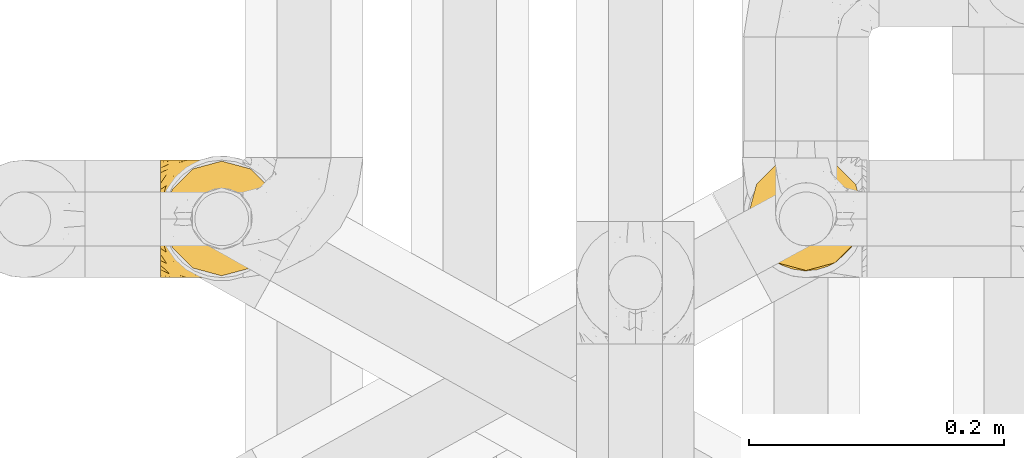
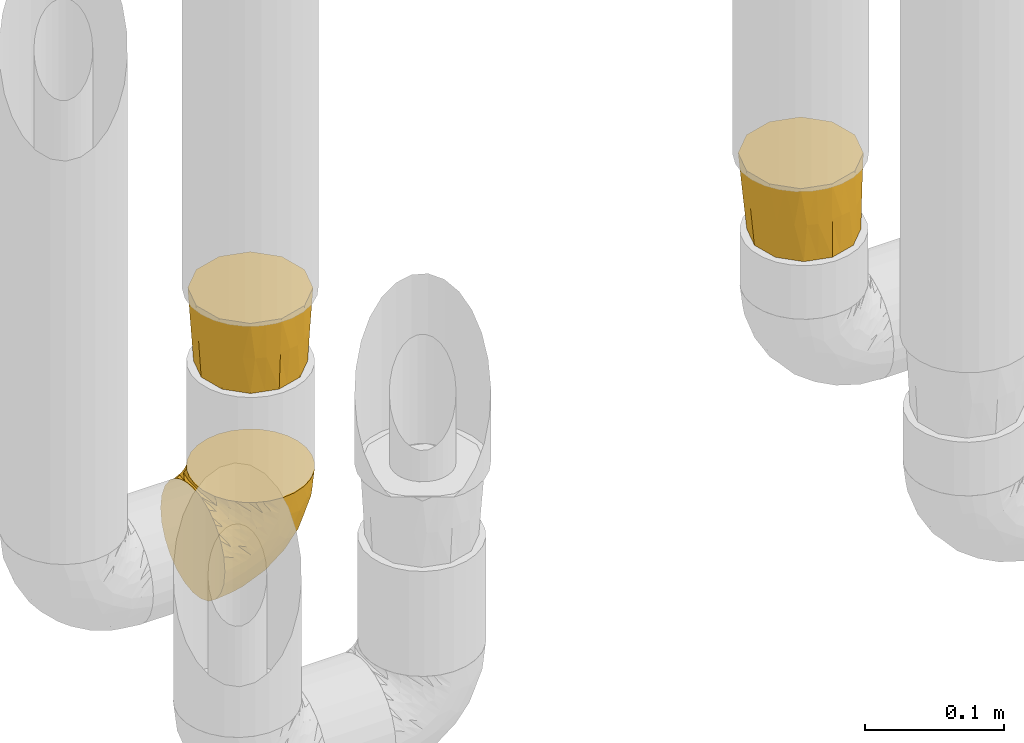
# One storey, part 177 of 827: 3 coverings.
"""IFC2X3 building model written with IfcOpenShell, lengths in millimetres."""

from ifc_helpers import new_model, entity, si_unit, converted_unit, derived_unit, direction, frame, origin, place, context, subcontext, project, spatial, faceted_brep, element, save


model = new_model("IFC2X3")

# Units and contexts
model_context = context("Model", 3, precision=0.01, world=origin(), true_north=direction((6.12303176911189e-17, 1.0)))
body_context = subcontext(model_context, "Body", "Model", "MODEL_VIEW")
ifc_project = project(units=[si_unit("LENGTHUNIT", "METRE", prefix="MILLI"), si_unit("AREAUNIT", "SQUARE_METRE"), si_unit("VOLUMEUNIT", "CUBIC_METRE"), converted_unit("PLANEANGLEUNIT", "DEGREE", entity("IfcRatioMeasure", 0.0174532925199433), si_unit("PLANEANGLEUNIT", "RADIAN"), dimensions=[0, 0, 0, 0, 0, 0, 0]), si_unit("MASSUNIT", "GRAM", prefix="KILO"), derived_unit("MASSDENSITYUNIT", [(si_unit("MASSUNIT", "GRAM", prefix="KILO"), 1), (si_unit("LENGTHUNIT", "METRE"), -3)]), derived_unit("MOMENTOFINERTIAUNIT", [(si_unit("LENGTHUNIT", "METRE"), 4)]), si_unit("TIMEUNIT", "SECOND"), si_unit("FREQUENCYUNIT", "HERTZ"), si_unit("THERMODYNAMICTEMPERATUREUNIT", "DEGREE_CELSIUS"), derived_unit("THERMALTRANSMITTANCEUNIT", [(si_unit("MASSUNIT", "GRAM", prefix="KILO"), 1), (si_unit("THERMODYNAMICTEMPERATUREUNIT", "KELVIN"), -1), (si_unit("TIMEUNIT", "SECOND"), -3)]), derived_unit("VOLUMETRICFLOWRATEUNIT", [(si_unit("LENGTHUNIT", "METRE"), 3), (si_unit("TIMEUNIT", "SECOND"), -1)]), derived_unit("MASSFLOWRATEUNIT", [(si_unit("MASSUNIT", "GRAM", prefix="KILO"), 1), (si_unit("TIMEUNIT", "SECOND"), -1)]), derived_unit("ROTATIONALFREQUENCYUNIT", [(si_unit("TIMEUNIT", "SECOND"), -1)]), si_unit("ELECTRICCURRENTUNIT", "AMPERE"), si_unit("ELECTRICVOLTAGEUNIT", "VOLT"), si_unit("POWERUNIT", "WATT"), si_unit("FORCEUNIT", "NEWTON", prefix="KILO"), si_unit("ILLUMINANCEUNIT", "LUX"), si_unit("LUMINOUSFLUXUNIT", "LUMEN"), si_unit("LUMINOUSINTENSITYUNIT", "CANDELA"), derived_unit("USERDEFINED", [(si_unit("MASSUNIT", "GRAM", prefix="KILO"), -1), (si_unit("LENGTHUNIT", "METRE"), -2), (si_unit("TIMEUNIT", "SECOND"), 3), (si_unit("LUMINOUSFLUXUNIT", "LUMEN"), 1)]), derived_unit("LINEARVELOCITYUNIT", [(si_unit("LENGTHUNIT", "METRE"), 1), (si_unit("TIMEUNIT", "SECOND"), -1)]), si_unit("PRESSUREUNIT", "PASCAL"), derived_unit("USERDEFINED", [(si_unit("LENGTHUNIT", "METRE"), -2), (si_unit("MASSUNIT", "GRAM", prefix="KILO"), 1), (si_unit("TIMEUNIT", "SECOND"), -2)]), derived_unit("LINEARFORCEUNIT", [(si_unit("MASSUNIT", "GRAM", prefix="KILO"), 1), (si_unit("LENGTHUNIT", "METRE"), 1), (si_unit("TIMEUNIT", "SECOND"), -2), (si_unit("LENGTHUNIT", "METRE"), -1)]), derived_unit("PLANARFORCEUNIT", [(si_unit("MASSUNIT", "GRAM", prefix="KILO"), 1), (si_unit("LENGTHUNIT", "METRE"), 1), (si_unit("TIMEUNIT", "SECOND"), -2), (si_unit("LENGTHUNIT", "METRE"), -2)])], contexts=[model_context])

# Site, building, storey
site_placement = place(None, origin())
site = spatial("IfcSite", under=ifc_project, at=site_placement, CompositionType="ELEMENT")
building_placement = place(site_placement, origin())
building = spatial("IfcBuilding", under=site, at=building_placement, CompositionType="ELEMENT")
storey_placement = place(building_placement, frame((0.0, 0.0, 28200.0)))
storey = spatial("IfcBuildingStorey", under=building, at=storey_placement, Name="08", CompositionType="ELEMENT", Elevation=28200.0)

# Coverings
covering_1_placement = place(storey_placement, frame((35225.75, 12958.41, 352.2)))
element("IfcCovering", 1, at=covering_1_placement, inside=storey, Name=":ADSK_", ObjectType=":ADSK_", PredefinedType="INSULATION", context=body_context, shape_type="Brep", body=[
    faceted_brep([(78.41, 11.68, 95.8), (85.72, 19.0, 95.8), (91.22, 27.76, 95.8), (94.64, 37.52, 95.8), (95.8, 47.8, 95.8), (94.64, 58.08, 95.8), (91.22, 67.85, 95.8), (85.71, 76.61, 95.8), (78.39, 83.92, 95.8), (69.63, 89.42, 95.8), (59.87, 92.84, 95.8), (49.6, 94.0, 95.8), (45.45, 93.53, 95.8), (42.38, 93.18, 95.8), (39.31, 92.84, 95.8), (34.43, 91.13, 95.8), (29.54, 89.42, 95.8), (25.16, 86.66, 95.8), (20.78, 83.91, 95.8), (17.13, 80.25, 95.8), (13.47, 76.59, 95.8), (7.97, 67.83, 95.8), (6.26, 62.95, 95.8), (4.55, 58.07, 95.8), (3.4, 47.8, 95.8), (4.55, 37.51, 95.8), (6.26, 32.63, 95.8), (7.97, 27.74, 95.8), (13.48, 18.98, 95.8), (17.14, 15.33, 95.8), (20.8, 11.67, 95.8), (25.18, 8.92, 95.8), (29.56, 6.17, 95.8), (34.44, 4.46, 95.8), (39.32, 2.75, 95.8), (42.39, 2.41, 95.8), (45.45, 2.06, 95.8), (49.6, 1.6, 95.8), (59.88, 2.75, 95.8), (69.65, 6.17, 95.8), (1.6, 47.8, 94.0), (1.6, 59.75, 92.42), (1.6, 70.9, 87.81), (1.6, 75.68, 84.13), (1.6, 80.46, 80.46), (1.6, 84.13, 75.68), (1.6, 87.81, 70.9), (1.6, 90.11, 65.32), (1.6, 92.42, 59.75), (1.6, 92.9, 56.14), (1.6, 93.17, 54.06), (1.6, 93.45, 51.97), (1.6, 94.0, 47.8), (1.6, 92.42, 35.84), (1.6, 87.81, 24.7), (1.6, 80.46, 15.13), (1.6, 70.9, 7.78), (1.6, 59.75, 3.17), (1.6, 47.8, 1.6), (1.6, 35.84, 3.17), (1.6, 24.7, 7.78), (1.6, 15.13, 15.13), (1.6, 7.78, 24.7), (1.6, 3.17, 35.84), (1.6, 1.6, 47.8), (1.6, 2.14, 51.97), (1.6, 2.69, 56.14), (1.6, 3.17, 59.75), (1.6, 5.48, 65.32), (1.6, 7.78, 70.9), (1.6, 11.46, 75.68), (1.6, 15.13, 80.46), (1.6, 19.91, 84.13), (1.6, 24.7, 87.81), (1.6, 35.84, 92.42), (36.81, 23.61, 15.84), (23.28, 31.99, 6.99), (45.8, 35.87, 14.39), (30.7, 47.8, 6.21), (21.2, 40.43, 4.26), (12.96, 47.8, 3.39), (66.19, 31.83, 31.2), (54.51, 23.37, 26.47), (17.98, 21.41, 11.44), (36.69, 3.07, 47.66), (35.54, 1.6, 61.85), (31.64, 1.6, 59.25), (27.75, 1.6, 56.65), (23.86, 1.6, 54.05), (19.96, 1.6, 51.45), (22.8, 13.45, 19.8), (42.67, 15.25, 26.22), (33.21, 8.07, 31.58), (59.45, 16.0, 38.36), (71.5, 17.34, 51.54), (62.66, 10.58, 51.6), (54.5, 5.34, 55.97), (47.57, 2.39, 62.88), (48.81, 8.36, 41.35), (74.98, 10.04, 82.24), (18.7, 2.59, 40.88), (15.75, 6.28, 29.0), (91.17, 34.28, 74.06), (85.28, 38.73, 54.53), (82.58, 27.25, 57.98), (75.78, 29.88, 43.81), (74.98, 38.6, 38.22), (67.27, 23.44, 38.33), (87.38, 25.25, 74.76), (82.04, 17.23, 76.85), (94.0, 47.8, 84.43), (77.8, 47.8, 40.43), (67.38, 47.8, 30.01), (56.2, 2.53, 78.67), (48.85, 1.6, 92.06), (48.11, 1.6, 88.32), (47.57, 1.6, 85.6), (47.03, 1.6, 82.88), (46.48, 1.6, 80.15), (45.94, 1.6, 77.43), (65.78, 5.71, 76.36), (17.24, 1.6, 50.91), (14.51, 1.6, 50.37), (11.79, 1.6, 49.82), (9.07, 1.6, 49.28), (7.2, 1.6, 48.91), (5.33, 1.6, 48.54), (91.18, 47.8, 66.69), (43.34, 1.6, 73.53), (40.74, 1.6, 69.64), (38.14, 1.6, 65.75), (72.73, 11.89, 66.13), (56.96, 47.8, 19.59), (62.23, 39.69, 24.64), (84.49, 47.8, 53.56), (43.83, 47.8, 12.9), (12.05, 13.84, 82.81), (18.95, 9.16, 81.22), (13.02, 15.79, 86.57), (8.34, 25.75, 92.75), (14.63, 16.09, 89.68), (11.09, 7.51, 72.26), (13.66, 3.99, 64.73), (20.08, 2.66, 62.45), (9.61, 3.16, 60.63), (9.48, 2.35, 56.91), (16.1, 2.23, 58.14), (3.42, 38.35, 93.7), (26.63, 6.18, 83.4), (33.72, 2.7, 75.54), (34.77, 2.93, 79.46), (6.75, 16.01, 82.28), (13.31, 9.08, 76.25), (21.11, 9.3, 84.69), (19.94, 11.68, 90.18), (8.67, 4.65, 65.12), (26.11, 3.65, 71.71), (29.3, 3.61, 75.21), (6.32, 12.8, 78.6), (39.92, 2.43, 87.27), (27.05, 6.83, 87.92), (6.04, 21.65, 86.94), (34.4, 3.7, 86.1), (2.87, 47.8, 94.52), (20.92, 3.37, 66.23), (27.43, 7.03, 91.08), (7.54, 7.87, 71.77), (18.45, 7.26, 76.21), (23.88, 3.41, 68.59), (7.77, 23.81, 89.94), (13.3, 86.5, 76.25), (11.09, 88.08, 72.26), (6.33, 82.79, 78.6), (9.07, 94.0, 49.28), (5.33, 94.0, 48.54), (14.51, 94.0, 50.37), (11.79, 94.0, 49.82), (3.42, 57.24, 93.7), (7.76, 71.76, 89.95), (47.03, 94.0, 82.88), (47.57, 94.0, 85.6), (48.85, 94.0, 92.06), (48.11, 94.0, 88.32), (14.62, 79.49, 89.68), (27.03, 88.75, 87.92), (20.08, 92.93, 62.45), (20.92, 92.22, 66.24), (27.75, 94.0, 56.65), (31.64, 94.0, 59.25), (9.61, 92.43, 60.63), (9.48, 93.24, 56.91), (8.33, 69.82, 92.76), (6.74, 79.57, 82.28), (12.04, 81.74, 82.81), (23.86, 94.0, 54.05), (19.96, 94.0, 51.45), (16.1, 93.36, 58.14), (19.93, 83.9, 90.18), (21.1, 86.28, 84.7), (39.92, 93.16, 87.25), (33.68, 92.88, 75.58), (29.28, 91.98, 75.2), (26.62, 89.41, 83.39), (26.08, 91.93, 71.7), (18.93, 86.42, 81.22), (27.87, 88.82, 90.73), (34.75, 92.66, 79.47), (6.04, 73.93, 86.94), (38.14, 94.0, 65.75), (12.79, 79.5, 86.75), (34.41, 91.89, 86.08), (45.94, 94.0, 77.43), (43.34, 94.0, 73.53), (40.74, 94.0, 69.64), (13.66, 91.6, 64.73), (17.24, 94.0, 50.91), (8.67, 90.94, 65.12), (35.54, 94.0, 61.85), (23.83, 92.16, 68.62), (18.43, 88.32, 76.22), (6.03, 86.13, 74.03), (46.48, 94.0, 80.15), (34.52, 93.2, 49.81), (21.2, 55.16, 4.26), (23.82, 82.02, 19.95), (41.32, 84.29, 30.61), (47.62, 76.94, 25.71), (52.66, 68.33, 22.43), (36.81, 71.98, 15.85), (49.75, 92.52, 60.69), (19.07, 92.9, 40.49), (45.8, 59.72, 14.39), (23.28, 63.6, 6.99), (21.35, 88.89, 29.56), (17.98, 74.18, 11.45), (82.57, 68.35, 57.98), (91.17, 61.33, 74.06), (85.27, 56.86, 54.52), (73.89, 68.62, 43.47), (66.19, 63.76, 31.2), (62.43, 72.19, 33.27), (63.53, 88.69, 64.26), (58.45, 92.19, 74.29), (67.16, 89.75, 80.41), (62.22, 55.9, 24.64), (81.54, 77.99, 73.62), (74.8, 85.21, 78.98), (75.83, 74.99, 53.69), (41.45, 90.23, 42.86), (76.72, 59.86, 41.67), (88.2, 70.75, 79.66), (71.6, 81.72, 58.41), (56.23, 86.53, 47.11), (59.44, 79.6, 38.37)], [[[0, 1, 2, 3, 4, 5, 6, 7, 8, 9, 10, 11, 12, 13, 14, 15, 16, 17, 18, 19, 20, 21, 22, 23, 24, 25, 26, 27, 28, 29, 30, 31, 32, 33, 34, 35, 36, 37, 38, 39]], [[40, 41, 42, 43, 44, 45, 46, 47, 48, 49, 50, 51, 52, 53, 54, 55, 56, 57, 58, 59, 60, 61, 62, 63, 64, 65, 66, 67, 68, 69, 70, 71, 72, 73, 74]], [[75, 76, 77]], [[78, 79, 80]], [[77, 81, 82]], [[76, 75, 83]], [[84, 85, 86, 87, 88, 89]], [[90, 91, 92]], [[76, 60, 59]], [[93, 94, 95]], [[90, 62, 61]], [[83, 61, 60]], [[96, 97, 84]], [[98, 93, 95]], [[0, 39, 99]], [[100, 84, 89]], [[62, 101, 63]], [[2, 102, 3]], [[92, 84, 100]], [[103, 102, 104]], [[103, 105, 106]], [[93, 107, 94]], [[1, 108, 2]], [[92, 101, 90]], [[108, 1, 109]], [[102, 110, 3]], [[93, 82, 107]], [[102, 108, 104]], [[111, 106, 112]], [[109, 0, 99]], [[113, 37, 114, 115, 116, 117, 118, 119]], [[120, 38, 113]], [[100, 89, 121, 122, 123, 124, 125, 126, 64]], [[127, 102, 103]], [[97, 119, 128, 129, 130, 85]], [[99, 120, 131]], [[132, 133, 77]], [[59, 80, 79]], [[1, 0, 109]], [[98, 84, 92]], [[94, 109, 131]], [[120, 39, 38]], [[93, 91, 82]], [[104, 94, 105]], [[97, 113, 119]], [[95, 120, 96]], [[83, 90, 61]], [[91, 93, 98]], [[64, 63, 100]], [[100, 63, 101]], [[77, 76, 79]], [[133, 106, 81]], [[84, 97, 85]], [[113, 96, 120]], [[113, 97, 96]], [[37, 113, 38]], [[110, 102, 127]], [[110, 4, 3]], [[103, 111, 134, 127]], [[90, 75, 91]], [[82, 81, 107]], [[91, 75, 82]], [[77, 82, 75]], [[76, 83, 60]], [[90, 83, 75]], [[105, 107, 81]], [[94, 131, 95]], [[105, 94, 107]], [[109, 94, 104]], [[120, 95, 131]], [[98, 95, 96]], [[84, 98, 96]], [[98, 92, 91]], [[106, 105, 81]], [[103, 104, 105]], [[112, 106, 133]], [[103, 106, 111]], [[112, 133, 132]], [[81, 77, 133]], [[77, 78, 135, 132]], [[120, 99, 39]], [[109, 99, 131]], [[59, 58, 80]], [[59, 79, 76]], [[90, 101, 62]], [[100, 101, 92]], [[2, 108, 102]], [[109, 104, 108]], [[78, 77, 79]], [[136, 137, 138]], [[27, 139, 140]], [[141, 142, 143]], [[144, 145, 121]], [[146, 89, 88]], [[147, 139, 25]], [[148, 149, 150]], [[136, 151, 152]], [[147, 40, 74]], [[24, 147, 25]], [[140, 153, 154]], [[33, 116, 34]], [[73, 72, 151]], [[114, 37, 36, 35, 34, 116, 115]], [[146, 155, 144]], [[156, 85, 130]], [[157, 149, 148]], [[151, 158, 152]], [[117, 33, 159]], [[29, 154, 160]], [[161, 74, 73]], [[162, 128, 119]], [[66, 65, 64, 126, 125, 124, 123, 122, 67]], [[163, 147, 24]], [[27, 140, 28]], [[149, 129, 150]], [[139, 27, 26, 25]], [[68, 144, 69]], [[129, 128, 150]], [[164, 87, 86]], [[130, 129, 149]], [[122, 145, 67]], [[154, 153, 148]], [[162, 119, 159]], [[165, 30, 160]], [[150, 160, 148]], [[128, 162, 150]], [[30, 165, 31]], [[145, 144, 68]], [[89, 146, 144]], [[87, 164, 143]], [[166, 155, 142]], [[88, 87, 143]], [[162, 160, 150]], [[160, 30, 29]], [[154, 29, 28]], [[140, 154, 28]], [[160, 154, 148]], [[140, 137, 153]], [[157, 148, 153]], [[156, 130, 157]], [[153, 137, 157]], [[157, 137, 156]], [[167, 137, 136]], [[168, 85, 156]], [[152, 168, 167]], [[167, 168, 156]], [[164, 152, 141]], [[71, 158, 72]], [[152, 167, 136]], [[88, 142, 146]], [[144, 155, 69]], [[146, 142, 155]], [[70, 166, 71]], [[142, 141, 166]], [[70, 69, 155]], [[141, 158, 71]], [[161, 73, 151]], [[138, 137, 140]], [[161, 136, 169]], [[136, 161, 151]], [[74, 161, 169]], [[152, 158, 141]], [[151, 72, 158]], [[168, 152, 164]], [[137, 167, 156]], [[164, 86, 168]], [[85, 168, 86]], [[116, 33, 117]], [[130, 149, 157]], [[67, 145, 68]], [[121, 89, 144]], [[145, 122, 121]], [[40, 147, 163]], [[169, 147, 74]], [[159, 33, 32]], [[162, 159, 32]], [[159, 119, 118, 117]], [[139, 147, 169]], [[139, 169, 138]], [[162, 32, 31]], [[141, 143, 164]], [[88, 143, 142]], [[71, 166, 141]], [[155, 166, 70]], [[139, 138, 140]], [[169, 136, 138]], [[160, 162, 165]], [[162, 31, 165]], [[170, 171, 172]], [[173, 174, 52, 51, 50, 49, 48, 175, 176]], [[177, 178, 41]], [[179, 15, 180]], [[12, 11, 181, 182, 180, 14, 13]], [[183, 21, 20]], [[19, 18, 184]], [[185, 186, 187]], [[186, 188, 187]], [[43, 172, 44]], [[189, 190, 47]], [[23, 22, 21, 191]], [[170, 192, 193]], [[40, 163, 177]], [[194, 195, 196]], [[24, 23, 177]], [[197, 198, 183]], [[199, 15, 179]], [[47, 46, 189]], [[200, 201, 202]], [[201, 203, 204]], [[205, 206, 184]], [[207, 41, 178]], [[16, 15, 199]], [[14, 180, 15]], [[202, 201, 198]], [[208, 201, 200]], [[163, 24, 177]], [[48, 47, 190]], [[196, 195, 189]], [[197, 184, 202]], [[204, 193, 209]], [[210, 211, 212]], [[206, 212, 213]], [[205, 17, 210]], [[184, 206, 202]], [[210, 212, 206]], [[185, 194, 214]], [[189, 215, 190]], [[216, 45, 214]], [[186, 171, 170]], [[189, 216, 196]], [[197, 20, 19]], [[194, 185, 187]], [[197, 183, 20]], [[184, 197, 19]], [[197, 202, 198]], [[206, 200, 202]], [[204, 183, 198]], [[201, 208, 203]], [[203, 208, 217]], [[204, 198, 201]], [[217, 188, 218]], [[193, 219, 170]], [[171, 186, 185]], [[170, 218, 186]], [[170, 219, 218]], [[42, 207, 192]], [[171, 220, 172]], [[216, 189, 46]], [[214, 194, 196]], [[44, 220, 45]], [[214, 196, 216]], [[216, 46, 45]], [[214, 45, 220]], [[192, 43, 42]], [[204, 203, 219]], [[207, 193, 192]], [[209, 193, 178]], [[41, 207, 42]], [[193, 207, 178]], [[43, 192, 172]], [[170, 172, 192]], [[204, 219, 193]], [[219, 203, 218]], [[217, 218, 203]], [[188, 186, 218]], [[206, 213, 200]], [[208, 200, 213]], [[199, 210, 16]], [[215, 189, 195]], [[215, 175, 190]], [[175, 48, 190]], [[199, 179, 221, 211]], [[210, 199, 211]], [[23, 191, 177]], [[40, 177, 41]], [[178, 177, 191]], [[21, 183, 191]], [[209, 191, 183]], [[205, 18, 17]], [[17, 16, 210]], [[171, 185, 214]], [[172, 220, 44]], [[214, 220, 171]], [[191, 209, 178]], [[204, 209, 183]], [[206, 205, 210]], [[18, 205, 184]], [[222, 195, 194, 187, 188, 217]], [[57, 223, 80]], [[224, 225, 226]], [[226, 227, 228]], [[229, 217, 208, 213, 212, 211]], [[230, 52, 174, 173, 176, 175, 215, 195]], [[231, 232, 228]], [[231, 78, 223]], [[223, 57, 232]], [[224, 233, 225]], [[233, 54, 53]], [[234, 232, 56]], [[56, 55, 234]], [[234, 224, 228]], [[235, 236, 237]], [[224, 55, 54]], [[238, 239, 240]], [[52, 230, 53]], [[241, 242, 243]], [[227, 244, 231]], [[11, 10, 242]], [[236, 6, 5]], [[7, 245, 8]], [[8, 246, 9]], [[238, 247, 235]], [[222, 229, 248]], [[242, 211, 221, 179, 180, 182, 181, 11]], [[233, 53, 230]], [[111, 112, 249]], [[250, 6, 236]], [[246, 251, 241]], [[6, 250, 7]], [[127, 236, 110]], [[248, 229, 252]], [[246, 8, 245]], [[235, 245, 250]], [[236, 5, 110]], [[235, 249, 238]], [[237, 236, 127]], [[243, 9, 246]], [[252, 229, 241]], [[56, 232, 57]], [[222, 230, 195]], [[225, 248, 252]], [[248, 233, 230]], [[54, 233, 224]], [[231, 228, 227]], [[244, 132, 231]], [[248, 225, 233]], [[226, 225, 253]], [[235, 250, 236]], [[245, 7, 250]], [[251, 246, 245]], [[243, 246, 241]], [[247, 245, 235]], [[252, 251, 253]], [[229, 222, 217]], [[230, 222, 248]], [[5, 4, 110]], [[237, 127, 134, 111]], [[238, 249, 239]], [[224, 234, 55]], [[232, 234, 228]], [[242, 241, 229]], [[10, 9, 243]], [[211, 242, 229]], [[10, 243, 242]], [[80, 223, 78]], [[80, 58, 57]], [[231, 223, 232]], [[227, 240, 239]], [[224, 226, 228]], [[240, 226, 253]], [[227, 239, 244]], [[226, 240, 227]], [[251, 247, 253]], [[240, 253, 247]], [[249, 235, 237]], [[237, 111, 249]], [[112, 132, 244]], [[112, 244, 249]], [[78, 231, 132, 135]], [[249, 244, 239]], [[247, 238, 240]], [[245, 247, 251]], [[251, 252, 241]], [[225, 252, 253]]]),
])
covering_2_placement = place(storey_placement, frame((35687.54, 12963.61, 495.0)))
element("IfcCovering", 2, at=covering_2_placement, inside=storey, Name=":ADSK_", ObjectType=":ADSK_", PredefinedType="INSULATION", context=body_context, shape_type="Brep", body=[
    faceted_brep([(85.57, 69.57, 64.0), (77.33, 77.81, 64.0), (69.1, 86.04, 64.0), (57.85, 89.06, 64.0), (46.6, 92.07, 64.0), (35.35, 89.06, 64.0), (24.1, 86.04, 64.0), (15.86, 77.81, 64.0), (7.62, 69.57, 64.0), (4.61, 58.32, 64.0), (1.6, 47.07, 64.0), (4.61, 35.82, 64.0), (7.62, 24.57, 64.0), (15.86, 16.33, 64.0), (24.1, 8.1, 64.0), (35.35, 5.08, 64.0), (46.6, 2.07, 64.0), (57.85, 5.08, 64.0), (69.1, 8.1, 64.0), (77.33, 16.33, 64.0), (85.57, 24.57, 64.0), (88.58, 35.82, 64.0), (91.6, 47.07, 64.0), (88.58, 58.32, 64.0), (82.1, 22.1, 0.0), (74.6, 14.59, 0.0), (67.1, 7.09, 0.0), (54.39, 3.68, 0.0), (46.6, 1.6, 0.0), (36.35, 4.34, 0.0), (26.1, 7.09, 0.0), (18.59, 14.59, 0.0), (11.09, 22.1, 0.0), (7.68, 34.8, 0.0), (5.6, 42.6, 0.0), (8.34, 52.85, 0.0), (11.09, 63.1, 0.0), (18.59, 70.6, 0.0), (26.1, 78.1, 0.0), (38.82, 81.51, 0.0), (46.6, 83.6, 0.0), (56.85, 80.85, 0.0), (67.1, 78.1, 0.0), (74.6, 70.6, 0.0), (82.1, 63.1, 0.0), (85.51, 50.37, 0.0), (87.6, 42.6, 0.0), (84.85, 32.35, 0.0), (30.14, 84.56, 32.0), (38.19, 87.19, 33.43), (46.6, 87.93, 32.75), (22.25, 80.28, 32.0), (4.94, 55.52, 32.0), (12.48, 71.01, 32.0), (7.79, 63.36, 32.0), (3.55, 44.89, 32.75), (6.87, 28.38, 32.0), (4.33, 36.52, 33.43), (11.15, 20.49, 32.0), (35.91, 3.18, 32.0), (20.42, 10.72, 32.0), (28.07, 6.03, 32.0), (46.6, 1.84, 32.85), (63.05, 5.11, 32.0), (55.0, 2.67, 33.43), (70.94, 9.39, 32.0), (88.25, 34.14, 32.0), (80.71, 18.66, 32.0), (85.4, 26.31, 32.0), (89.65, 44.89, 32.85), (86.32, 61.29, 32.0), (88.86, 53.34, 33.43), (82.04, 69.18, 32.0), (57.28, 86.48, 32.0), (72.77, 78.95, 32.0), (65.12, 83.64, 32.0)], [[[0, 1, 2, 3, 4, 5, 6, 7, 8, 9, 10, 11, 12, 13, 14, 15, 16, 17, 18, 19, 20, 21, 22, 23]], [[24, 25, 26, 27, 28, 29, 30, 31, 32, 33, 34, 35, 36, 37, 38, 39, 40, 41, 42, 43, 44, 45, 46, 47]], [[39, 48, 49]], [[39, 50, 40]], [[48, 39, 38]], [[6, 5, 48]], [[51, 6, 48]], [[48, 5, 49]], [[10, 9, 52]], [[53, 51, 37]], [[51, 48, 38]], [[8, 53, 54]], [[54, 53, 36]], [[37, 36, 53]], [[51, 38, 37]], [[50, 49, 4]], [[53, 7, 51]], [[7, 6, 51]], [[7, 53, 8]], [[52, 9, 54]], [[54, 35, 52]], [[54, 36, 35]], [[4, 49, 5]], [[9, 8, 54]], [[34, 55, 10, 52]], [[39, 49, 50]], [[34, 52, 35]], [[33, 56, 57]], [[33, 55, 34]], [[56, 33, 32]], [[12, 11, 56]], [[58, 12, 56]], [[56, 11, 57]], [[16, 15, 59]], [[60, 58, 31]], [[58, 56, 32]], [[14, 60, 61]], [[61, 60, 30]], [[31, 30, 60]], [[58, 32, 31]], [[55, 57, 10]], [[60, 13, 58]], [[13, 12, 58]], [[13, 60, 14]], [[59, 15, 61]], [[61, 29, 59]], [[61, 30, 29]], [[10, 57, 11]], [[15, 14, 61]], [[28, 62, 16, 59]], [[33, 57, 55]], [[28, 59, 29]], [[27, 63, 64]], [[27, 62, 28]], [[63, 27, 26]], [[18, 17, 63]], [[65, 18, 63]], [[63, 17, 64]], [[22, 21, 66]], [[67, 65, 25]], [[65, 63, 26]], [[20, 67, 68]], [[68, 67, 24]], [[25, 24, 67]], [[65, 26, 25]], [[62, 64, 16]], [[67, 19, 65]], [[19, 18, 65]], [[19, 67, 20]], [[66, 21, 68]], [[68, 47, 66]], [[68, 24, 47]], [[16, 64, 17]], [[21, 20, 68]], [[46, 69, 22, 66]], [[27, 64, 62]], [[46, 66, 47]], [[45, 70, 71]], [[45, 69, 46]], [[70, 45, 44]], [[0, 23, 70]], [[72, 0, 70]], [[70, 23, 71]], [[4, 3, 73]], [[74, 72, 43]], [[72, 70, 44]], [[2, 74, 75]], [[75, 74, 42]], [[43, 42, 74]], [[72, 44, 43]], [[69, 71, 22]], [[74, 1, 72]], [[1, 0, 72]], [[1, 74, 2]], [[73, 3, 75]], [[75, 41, 73]], [[75, 42, 41]], [[22, 71, 23]], [[3, 2, 75]], [[40, 50, 4, 73]], [[45, 71, 69]], [[40, 73, 41]]]),
])
covering_3_placement = place(storey_placement, frame((35228.75, 12959.94, 540.0)))
element("IfcCovering", 3, at=covering_3_placement, inside=storey, Name=":ADSK_", ObjectType=":ADSK_", PredefinedType="INSULATION", context=body_context, shape_type="Brep", body=[
    faceted_brep([(15.86, 15.86, 64.0), (24.1, 7.62, 64.0), (35.35, 4.61, 64.0), (46.6, 1.6, 64.0), (57.85, 4.61, 64.0), (69.1, 7.62, 64.0), (77.33, 15.86, 64.0), (85.57, 24.1, 64.0), (88.58, 35.35, 64.0), (91.6, 46.6, 64.0), (88.58, 57.85, 64.0), (85.57, 69.1, 64.0), (77.33, 77.33, 64.0), (69.1, 85.57, 64.0), (57.85, 88.58, 64.0), (46.6, 91.6, 64.0), (35.35, 88.58, 64.0), (24.1, 85.57, 64.0), (15.86, 77.33, 64.0), (7.62, 69.1, 64.0), (4.61, 57.85, 64.0), (1.6, 46.6, 64.0), (4.61, 35.35, 64.0), (7.62, 24.1, 64.0), (11.09, 66.77, 0.0), (18.59, 74.27, 0.0), (26.1, 81.78, 0.0), (38.8, 85.18, 0.0), (46.6, 87.27, 0.0), (56.85, 84.52, 0.0), (67.1, 81.78, 0.0), (74.6, 74.27, 0.0), (82.1, 66.77, 0.0), (85.51, 54.06, 0.0), (87.6, 46.27, 0.0), (84.85, 36.02, 0.0), (82.1, 25.77, 0.0), (74.6, 18.26, 0.0), (67.1, 10.76, 0.0), (54.39, 7.36, 0.0), (46.6, 5.27, 0.0), (36.35, 8.01, 0.0), (26.1, 10.76, 0.0), (18.59, 18.26, 0.0), (11.09, 25.77, 0.0), (7.68, 38.47, 0.0), (5.6, 46.27, 0.0), (8.34, 56.52, 0.0), (63.05, 6.7, 32.0), (55.0, 4.18, 33.43), (46.6, 3.38, 32.85), (70.94, 10.99, 32.0), (88.25, 35.74, 32.0), (80.71, 20.25, 32.0), (85.4, 27.91, 32.0), (89.65, 46.44, 32.85), (86.32, 62.89, 32.0), (88.86, 54.85, 33.43), (82.04, 70.78, 32.0), (57.28, 88.08, 32.0), (72.77, 80.55, 32.0), (65.12, 85.24, 32.0), (46.6, 89.49, 32.84), (30.14, 86.16, 32.0), (38.19, 88.7, 33.43), (22.25, 81.88, 32.0), (4.94, 57.12, 32.0), (12.48, 72.61, 32.0), (7.79, 64.96, 32.0), (3.54, 46.44, 32.84), (6.87, 29.98, 32.0), (4.33, 38.03, 33.43), (11.15, 22.09, 32.0), (35.91, 4.78, 32.0), (20.42, 12.32, 32.0), (28.07, 7.63, 32.0)], [[[0, 1, 2, 3, 4, 5, 6, 7, 8, 9, 10, 11, 12, 13, 14, 15, 16, 17, 18, 19, 20, 21, 22, 23]], [[24, 25, 26, 27, 28, 29, 30, 31, 32, 33, 34, 35, 36, 37, 38, 39, 40, 41, 42, 43, 44, 45, 46, 47]], [[39, 48, 49]], [[39, 50, 40]], [[48, 39, 38]], [[5, 4, 48]], [[51, 5, 48]], [[48, 4, 49]], [[9, 8, 52]], [[53, 51, 37]], [[51, 48, 38]], [[7, 53, 54]], [[54, 53, 36]], [[37, 36, 53]], [[51, 38, 37]], [[50, 49, 3]], [[53, 6, 51]], [[6, 5, 51]], [[6, 53, 7]], [[52, 8, 54]], [[54, 35, 52]], [[54, 36, 35]], [[3, 49, 4]], [[8, 7, 54]], [[34, 55, 9, 52]], [[39, 49, 50]], [[34, 52, 35]], [[33, 56, 57]], [[33, 55, 34]], [[56, 33, 32]], [[11, 10, 56]], [[58, 11, 56]], [[56, 10, 57]], [[15, 14, 59]], [[60, 58, 31]], [[58, 56, 32]], [[13, 60, 61]], [[61, 60, 30]], [[31, 30, 60]], [[58, 32, 31]], [[55, 57, 9]], [[60, 12, 58]], [[12, 11, 58]], [[12, 60, 13]], [[59, 14, 61]], [[61, 29, 59]], [[61, 30, 29]], [[9, 57, 10]], [[14, 13, 61]], [[28, 62, 15, 59]], [[33, 57, 55]], [[28, 59, 29]], [[27, 63, 64]], [[27, 62, 28]], [[63, 27, 26]], [[17, 16, 63]], [[65, 17, 63]], [[63, 16, 64]], [[21, 20, 66]], [[67, 65, 25]], [[65, 63, 26]], [[19, 67, 68]], [[68, 67, 24]], [[25, 24, 67]], [[65, 26, 25]], [[62, 64, 15]], [[67, 18, 65]], [[18, 17, 65]], [[18, 67, 19]], [[66, 20, 68]], [[68, 47, 66]], [[68, 24, 47]], [[15, 64, 16]], [[20, 19, 68]], [[46, 69, 21, 66]], [[27, 64, 62]], [[46, 66, 47]], [[45, 70, 71]], [[45, 69, 46]], [[70, 45, 44]], [[23, 22, 70]], [[72, 23, 70]], [[70, 22, 71]], [[3, 2, 73]], [[74, 72, 43]], [[72, 70, 44]], [[1, 74, 75]], [[75, 74, 42]], [[43, 42, 74]], [[72, 44, 43]], [[69, 71, 21]], [[74, 0, 72]], [[0, 23, 72]], [[0, 74, 1]], [[73, 2, 75]], [[75, 41, 73]], [[75, 42, 41]], [[21, 71, 22]], [[2, 1, 75]], [[40, 50, 3, 73]], [[45, 71, 69]], [[40, 73, 41]]]),
])

save(model, "model.ifc")
